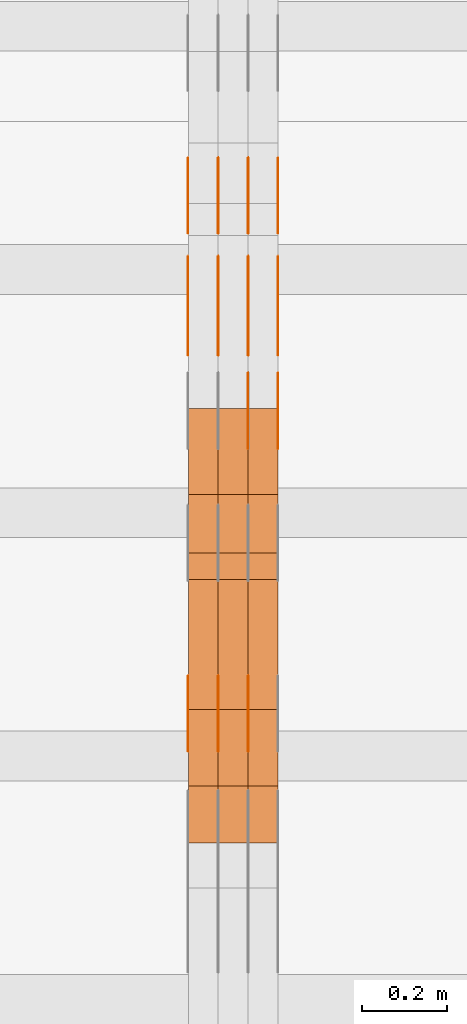
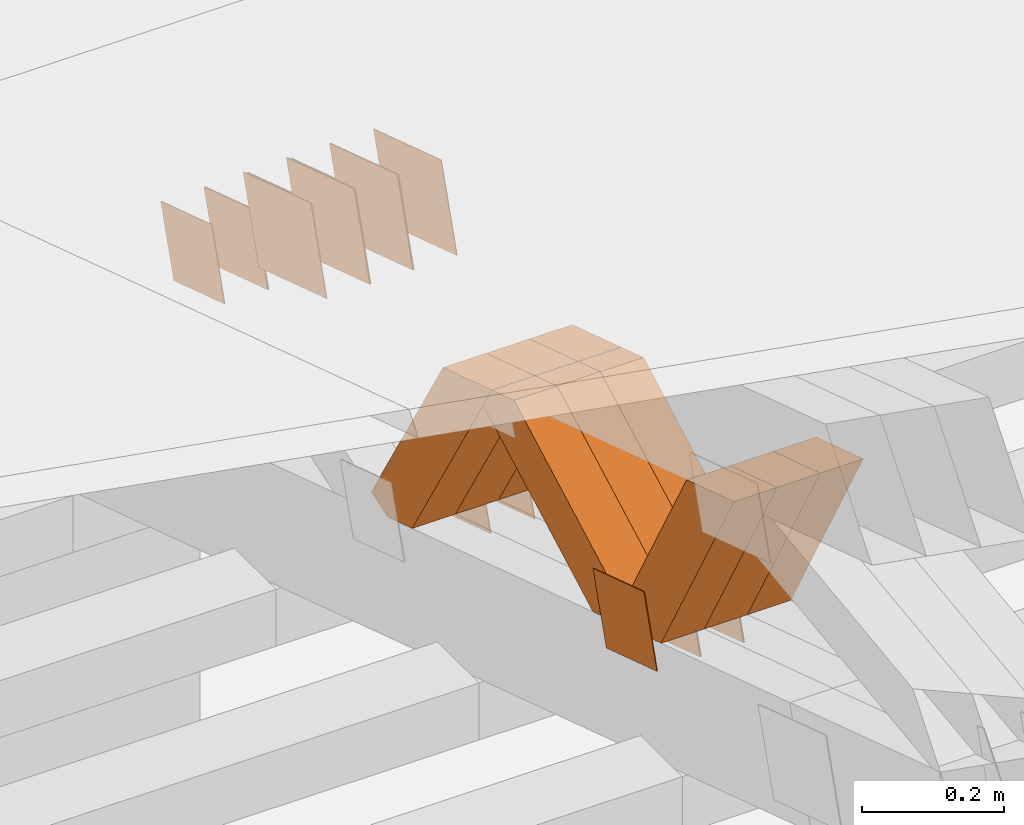
# One storey, part 196 of 385: 28 proxies.
"""IFC2X3 building model written with IfcOpenShell, lengths in millimetres."""

from ifc_helpers import new_model, entity, si_unit, converted_unit, derived_unit, direction, frame, origin, place, context, subcontext, project, spatial, polyline, outline, extrude, source, transform, mapped, material, type_object, type_shapes, element, save


model = new_model("IFC2X3")

# Units and contexts
model_context = context("Model", 3, precision=0.01, world=origin(), true_north=direction((6.12303176911189e-17, 1.0)))
body_context = subcontext(model_context, "Body", "Model", "MODEL_VIEW")
ifc_project = project(units=[si_unit("LENGTHUNIT", "METRE", prefix="MILLI"), si_unit("AREAUNIT", "SQUARE_METRE"), si_unit("VOLUMEUNIT", "CUBIC_METRE"), converted_unit("PLANEANGLEUNIT", "DEGREE", entity("IfcRatioMeasure", 0.0174532925199433), si_unit("PLANEANGLEUNIT", "RADIAN"), dimensions=[0, 0, 0, 0, 0, 0, 0]), si_unit("MASSUNIT", "GRAM", prefix="KILO"), derived_unit("MASSDENSITYUNIT", [(si_unit("MASSUNIT", "GRAM", prefix="KILO"), 1), (si_unit("LENGTHUNIT", "METRE"), -3)]), si_unit("TIMEUNIT", "SECOND"), si_unit("FREQUENCYUNIT", "HERTZ"), si_unit("THERMODYNAMICTEMPERATUREUNIT", "DEGREE_CELSIUS"), derived_unit("THERMALTRANSMITTANCEUNIT", [(si_unit("MASSUNIT", "GRAM", prefix="KILO"), 1), (si_unit("THERMODYNAMICTEMPERATUREUNIT", "KELVIN"), -1), (si_unit("TIMEUNIT", "SECOND"), -3)]), derived_unit("VOLUMETRICFLOWRATEUNIT", [(si_unit("LENGTHUNIT", "METRE"), 3), (si_unit("TIMEUNIT", "SECOND"), -1)]), si_unit("ELECTRICCURRENTUNIT", "AMPERE"), si_unit("ELECTRICVOLTAGEUNIT", "VOLT"), si_unit("POWERUNIT", "WATT"), si_unit("FORCEUNIT", "NEWTON", prefix="KILO"), si_unit("ILLUMINANCEUNIT", "LUX"), si_unit("LUMINOUSFLUXUNIT", "LUMEN"), si_unit("LUMINOUSINTENSITYUNIT", "CANDELA"), derived_unit("USERDEFINED", [(si_unit("MASSUNIT", "GRAM", prefix="KILO"), -1), (si_unit("LENGTHUNIT", "METRE"), -2), (si_unit("TIMEUNIT", "SECOND"), 3), (si_unit("LUMINOUSFLUXUNIT", "LUMEN"), 1)]), derived_unit("LINEARVELOCITYUNIT", [(si_unit("LENGTHUNIT", "METRE"), 1), (si_unit("TIMEUNIT", "SECOND"), -1)]), si_unit("PRESSUREUNIT", "PASCAL"), derived_unit("USERDEFINED", [(si_unit("LENGTHUNIT", "METRE"), -2), (si_unit("MASSUNIT", "GRAM", prefix="KILO"), 1), (si_unit("TIMEUNIT", "SECOND"), -2)])], contexts=[model_context])

# Site, building, storey
site_placement = place(None, origin())
site = spatial("IfcSite", under=ifc_project, at=site_placement, CompositionType="ELEMENT")
building_placement = place(site_placement, origin())
building = spatial("IfcBuilding", under=site, at=building_placement, CompositionType="ELEMENT")
storey_placement = place(building_placement, origin())
storey = spatial("IfcBuildingStorey", under=building, at=storey_placement, Name="Default", CompositionType="ELEMENT", Elevation=0.0)

# Proxies
ifc_material_1 = material(Name="IfcSurfaceStyle #212218")
building_element_proxy_type_1 = type_object("IfcBuildingElementProxyType", PredefinedType="NOTDEFINED", material=ifc_material_1)
shared_shape_1 = source(origin(), body_context, "Body", "SweptSolid", [
    extrude(outline(polyline([(-74.9998605591059, -59.9999264677526), (74.999875428623, -59.9999264677526), (74.9998605591068, 59.9999264677526), (-74.9998754286239, 59.9999264677526), (-74.9998605591059, -59.9999264677526)])), frame((75.0000889884782, 60.0000460315623, 0.0), z_axis=(0.0, 0.0, 1.0), x_axis=(-1.0, 0.0, 0.0)), (0.0, 0.0, 1.0), 1.3),
])
type_shapes(building_element_proxy_type_1, [shared_shape_1])
proxy_1_placement = place(building_placement, frame((15386.3, 20621.9679769682, 2241.76551219004), z_axis=(-1.0, 0.0, 0.0), x_axis=(0.0, -0.951056516295154, 0.309016994374948)))
element("IfcBuildingElementProxy", 1, at=proxy_1_placement, inside=storey, type_object=building_element_proxy_type_1, material=ifc_material_1, context=body_context, shape_type="MappedRepresentation", body=[
    mapped(shared_shape_1, transform((0.0, 0.0, 0.0), scale=1.0)),
])
ifc_material_2 = material(Name="IfcSurfaceStyle #212161")
building_element_proxy_type_2 = type_object("IfcBuildingElementProxyType", PredefinedType="NOTDEFINED", material=ifc_material_2)
shared_shape_2 = source(origin(), body_context, "Body", "SweptSolid", [
    extrude(outline(polyline([(-74.9998605591059, -59.9999264677526), (74.999875428623, -59.9999264677526), (74.9998605591068, 59.9999264677526), (-74.9998754286239, 59.9999264677526), (-74.9998605591059, -59.9999264677526)])), frame((75.0000889884782, 60.0000460315623, 0.0), z_axis=(0.0, 0.0, 1.0), x_axis=(-1.0, 0.0, 0.0)), (0.0, 0.0, 1.0), 1.3),
])
type_shapes(building_element_proxy_type_2, [shared_shape_2])
proxy_2_placement = place(building_placement, frame((15315.0, 20621.9679769682, 2241.76551219004), z_axis=(-1.0, 0.0, 0.0), x_axis=(0.0, -0.951056516295154, 0.309016994374948)))
element("IfcBuildingElementProxy", 2, at=proxy_2_placement, inside=storey, type_object=building_element_proxy_type_2, material=ifc_material_2, context=body_context, shape_type="MappedRepresentation", body=[
    mapped(shared_shape_2, transform((0.0, 0.0, 0.0), scale=1.0)),
])
ifc_material_3 = material(Name="IfcSurfaceStyle #212104")
building_element_proxy_type_3 = type_object("IfcBuildingElementProxyType", PredefinedType="NOTDEFINED", material=ifc_material_3)
shared_shape_3 = source(origin(), body_context, "Body", "SweptSolid", [
    extrude(outline(polyline([(-74.9998605591059, -59.9999264677526), (74.999875428623, -59.9999264677526), (74.9998605591068, 59.9999264677526), (-74.9998754286239, 59.9999264677526), (-74.9998605591059, -59.9999264677526)])), frame((75.0000889884782, 60.0000460315623, 0.0), z_axis=(0.0, 0.0, 1.0), x_axis=(-1.0, 0.0, 0.0)), (0.0, 0.0, 1.0), 1.3),
])
type_shapes(building_element_proxy_type_3, [shared_shape_3])
proxy_3_placement = place(building_placement, frame((15316.3, 20621.9679769682, 2241.76551219004), z_axis=(-1.0, 0.0, 0.0), x_axis=(0.0, -0.951056516295154, 0.309016994374948)))
element("IfcBuildingElementProxy", 3, at=proxy_3_placement, inside=storey, type_object=building_element_proxy_type_3, material=ifc_material_3, context=body_context, shape_type="MappedRepresentation", body=[
    mapped(shared_shape_3, transform((0.0, 0.0, 0.0), scale=1.0)),
])
ifc_material_4 = material(Name="IfcSurfaceStyle #212047")
building_element_proxy_type_4 = type_object("IfcBuildingElementProxyType", PredefinedType="NOTDEFINED", material=ifc_material_4)
shared_shape_4 = source(origin(), body_context, "Body", "SweptSolid", [
    extrude(outline(polyline([(-74.9998605591059, -59.9999264677526), (74.999875428623, -59.9999264677526), (74.9998605591068, 59.9999264677526), (-74.9998754286239, 59.9999264677526), (-74.9998605591059, -59.9999264677526)])), frame((75.0000889884782, 60.0000460315623, 0.0), z_axis=(0.0, 0.0, 1.0), x_axis=(-1.0, 0.0, 0.0)), (0.0, 0.0, 1.0), 1.29999999999999),
])
type_shapes(building_element_proxy_type_4, [shared_shape_4])
proxy_4_placement = place(building_placement, frame((15245.0, 20621.9679769682, 2241.76551219004), z_axis=(-1.0, 0.0, 0.0), x_axis=(0.0, -0.951056516295154, 0.309016994374948)))
element("IfcBuildingElementProxy", 4, at=proxy_4_placement, inside=storey, type_object=building_element_proxy_type_4, material=ifc_material_4, context=body_context, shape_type="MappedRepresentation", body=[
    mapped(shared_shape_4, transform((0.0, 0.0, 0.0), scale=1.0)),
])
ifc_material_5 = material(Name="IfcSurfaceStyle #211990")
building_element_proxy_type_5 = type_object("IfcBuildingElementProxyType", PredefinedType="NOTDEFINED", material=ifc_material_5)
shared_shape_5 = source(origin(), body_context, "Body", "SweptSolid", [
    extrude(outline(polyline([(-74.9998605591059, -59.9999264677526), (74.999875428623, -59.9999264677526), (74.9998605591068, 59.9999264677526), (-74.9998754286239, 59.9999264677526), (-74.9998605591059, -59.9999264677526)])), frame((75.0000889884782, 60.0000460315623, 0.0), z_axis=(0.0, 0.0, 1.0), x_axis=(-1.0, 0.0, 0.0)), (0.0, 0.0, 1.0), 1.29999999999999),
])
type_shapes(building_element_proxy_type_5, [shared_shape_5])
proxy_5_placement = place(building_placement, frame((15246.3, 20621.9679769682, 2241.76551219004), z_axis=(-1.0, 0.0, 0.0), x_axis=(0.0, -0.951056516295154, 0.309016994374948)))
element("IfcBuildingElementProxy", 5, at=proxy_5_placement, inside=storey, type_object=building_element_proxy_type_5, material=ifc_material_5, context=body_context, shape_type="MappedRepresentation", body=[
    mapped(shared_shape_5, transform((0.0, 0.0, 0.0), scale=1.0)),
])
ifc_material_6 = material(Name="IfcSurfaceStyle #211933")
building_element_proxy_type_6 = type_object("IfcBuildingElementProxyType", PredefinedType="NOTDEFINED", material=ifc_material_6)
shared_shape_6 = source(origin(), body_context, "Body", "SweptSolid", [
    extrude(outline(polyline([(-74.9998605591059, -59.9999264677526), (74.999875428623, -59.9999264677526), (74.9998605591068, 59.9999264677526), (-74.9998754286239, 59.9999264677526), (-74.9998605591059, -59.9999264677526)])), frame((75.0000889884782, 60.0000460315623, 0.0), z_axis=(0.0, 0.0, 1.0), x_axis=(-1.0, 0.0, 0.0)), (0.0, 0.0, 1.0), 1.29999999999999),
])
type_shapes(building_element_proxy_type_6, [shared_shape_6])
proxy_6_placement = place(building_placement, frame((15175.0, 20621.9679769682, 2241.76551219004), z_axis=(-1.0, 0.0, 0.0), x_axis=(0.0, -0.951056516295154, 0.309016994374948)))
element("IfcBuildingElementProxy", 6, at=proxy_6_placement, inside=storey, type_object=building_element_proxy_type_6, material=ifc_material_6, context=body_context, shape_type="MappedRepresentation", body=[
    mapped(shared_shape_6, transform((0.0, 0.0, 0.0), scale=1.0)),
])
ifc_material_7 = material(Name="IfcSurfaceStyle #210508")
building_element_proxy_type_7 = type_object("IfcBuildingElementProxyType", PredefinedType="NOTDEFINED", material=ifc_material_7)
shared_shape_7 = source(origin(), body_context, "Body", "SweptSolid", [
    extrude(outline(polyline([(-100.000260677523, -72.0000050220369), (100.000341220114, -72.0000050220369), (99.9997962944585, 72.0000050220369), (-99.9998768370492, 72.0000050220369), (-100.000260677523, -72.0000050220369)])), frame((100.000341220114, 72.0001826453454, 0.0), z_axis=(0.0, 0.0, 1.0), x_axis=(-1.0, 0.0, 0.0)), (0.0, 0.0, 1.0), 1.3),
])
type_shapes(building_element_proxy_type_7, [shared_shape_7])
proxy_7_placement = place(building_placement, frame((15386.3, 20382.8706354426, 2409.35285895246), z_axis=(-1.0, 0.0, 0.0), x_axis=(0.0, -0.951056516295154, 0.309016994374948)))
element("IfcBuildingElementProxy", 7, at=proxy_7_placement, inside=storey, type_object=building_element_proxy_type_7, material=ifc_material_7, context=body_context, shape_type="MappedRepresentation", body=[
    mapped(shared_shape_7, transform((0.0, 0.0, 0.0), scale=1.0)),
])
ifc_material_8 = material(Name="IfcSurfaceStyle #210451")
building_element_proxy_type_8 = type_object("IfcBuildingElementProxyType", PredefinedType="NOTDEFINED", material=ifc_material_8)
shared_shape_8 = source(origin(), body_context, "Body", "SweptSolid", [
    extrude(outline(polyline([(-100.000260677523, -72.0000050220369), (100.000341220114, -72.0000050220369), (99.9997962944585, 72.0000050220369), (-99.9998768370492, 72.0000050220369), (-100.000260677523, -72.0000050220369)])), frame((100.000341220114, 72.0001826453454, 0.0), z_axis=(0.0, 0.0, 1.0), x_axis=(-1.0, 0.0, 0.0)), (0.0, 0.0, 1.0), 1.3),
])
type_shapes(building_element_proxy_type_8, [shared_shape_8])
proxy_8_placement = place(building_placement, frame((15315.0, 20382.8706354426, 2409.35285895246), z_axis=(-1.0, 0.0, 0.0), x_axis=(0.0, -0.951056516295154, 0.309016994374948)))
element("IfcBuildingElementProxy", 8, at=proxy_8_placement, inside=storey, type_object=building_element_proxy_type_8, material=ifc_material_8, context=body_context, shape_type="MappedRepresentation", body=[
    mapped(shared_shape_8, transform((0.0, 0.0, 0.0), scale=1.0)),
])
ifc_material_9 = material(Name="IfcSurfaceStyle #210394")
building_element_proxy_type_9 = type_object("IfcBuildingElementProxyType", PredefinedType="NOTDEFINED", material=ifc_material_9)
shared_shape_9 = source(origin(), body_context, "Body", "SweptSolid", [
    extrude(outline(polyline([(-100.000260677523, -72.0000050220369), (100.000341220114, -72.0000050220369), (99.9997962944585, 72.0000050220369), (-99.9998768370492, 72.0000050220369), (-100.000260677523, -72.0000050220369)])), frame((100.000341220114, 72.0001826453454, 0.0), z_axis=(0.0, 0.0, 1.0), x_axis=(-1.0, 0.0, 0.0)), (0.0, 0.0, 1.0), 1.3),
])
type_shapes(building_element_proxy_type_9, [shared_shape_9])
proxy_9_placement = place(building_placement, frame((15316.3, 20382.8706354426, 2409.35285895246), z_axis=(-1.0, 0.0, 0.0), x_axis=(0.0, -0.951056516295154, 0.309016994374948)))
element("IfcBuildingElementProxy", 9, at=proxy_9_placement, inside=storey, type_object=building_element_proxy_type_9, material=ifc_material_9, context=body_context, shape_type="MappedRepresentation", body=[
    mapped(shared_shape_9, transform((0.0, 0.0, 0.0), scale=1.0)),
])
ifc_material_10 = material(Name="IfcSurfaceStyle #210337")
building_element_proxy_type_10 = type_object("IfcBuildingElementProxyType", PredefinedType="NOTDEFINED", material=ifc_material_10)
shared_shape_10 = source(origin(), body_context, "Body", "SweptSolid", [
    extrude(outline(polyline([(-100.000260677523, -72.0000050220369), (100.000341220114, -72.0000050220369), (99.9997962944585, 72.0000050220369), (-99.9998768370492, 72.0000050220369), (-100.000260677523, -72.0000050220369)])), frame((100.000341220114, 72.0001826453454, 0.0), z_axis=(0.0, 0.0, 1.0), x_axis=(-1.0, 0.0, 0.0)), (0.0, 0.0, 1.0), 1.29999999999998),
])
type_shapes(building_element_proxy_type_10, [shared_shape_10])
proxy_10_placement = place(building_placement, frame((15245.0, 20382.8706354426, 2409.35285895246), z_axis=(-1.0, 0.0, 0.0), x_axis=(0.0, -0.951056516295154, 0.309016994374948)))
element("IfcBuildingElementProxy", 10, at=proxy_10_placement, inside=storey, type_object=building_element_proxy_type_10, material=ifc_material_10, context=body_context, shape_type="MappedRepresentation", body=[
    mapped(shared_shape_10, transform((0.0, 0.0, 0.0), scale=1.0)),
])
ifc_material_11 = material(Name="IfcSurfaceStyle #210280")
building_element_proxy_type_11 = type_object("IfcBuildingElementProxyType", PredefinedType="NOTDEFINED", material=ifc_material_11)
shared_shape_11 = source(origin(), body_context, "Body", "SweptSolid", [
    extrude(outline(polyline([(-100.000260677523, -72.0000050220369), (100.000341220114, -72.0000050220369), (99.9997962944585, 72.0000050220369), (-99.9998768370492, 72.0000050220369), (-100.000260677523, -72.0000050220369)])), frame((100.000341220114, 72.0001826453454, 0.0), z_axis=(0.0, 0.0, 1.0), x_axis=(-1.0, 0.0, 0.0)), (0.0, 0.0, 1.0), 1.29999999999998),
])
type_shapes(building_element_proxy_type_11, [shared_shape_11])
proxy_11_placement = place(building_placement, frame((15246.3, 20382.8706354426, 2409.35285895246), z_axis=(-1.0, 0.0, 0.0), x_axis=(0.0, -0.951056516295154, 0.309016994374948)))
element("IfcBuildingElementProxy", 11, at=proxy_11_placement, inside=storey, type_object=building_element_proxy_type_11, material=ifc_material_11, context=body_context, shape_type="MappedRepresentation", body=[
    mapped(shared_shape_11, transform((0.0, 0.0, 0.0), scale=1.0)),
])
ifc_material_12 = material(Name="IfcSurfaceStyle #210223")
building_element_proxy_type_12 = type_object("IfcBuildingElementProxyType", PredefinedType="NOTDEFINED", material=ifc_material_12)
shared_shape_12 = source(origin(), body_context, "Body", "SweptSolid", [
    extrude(outline(polyline([(-100.000260677523, -72.0000050220369), (100.000341220114, -72.0000050220369), (99.9997962944585, 72.0000050220369), (-99.9998768370492, 72.0000050220369), (-100.000260677523, -72.0000050220369)])), frame((100.000341220114, 72.0001826453454, 0.0), z_axis=(0.0, 0.0, 1.0), x_axis=(-1.0, 0.0, 0.0)), (0.0, 0.0, 1.0), 1.29999999999999),
])
type_shapes(building_element_proxy_type_12, [shared_shape_12])
proxy_12_placement = place(building_placement, frame((15175.0, 20382.8706354426, 2409.35285895246), z_axis=(-1.0, 0.0, 0.0), x_axis=(0.0, -0.951056516295154, 0.309016994374948)))
element("IfcBuildingElementProxy", 12, at=proxy_12_placement, inside=storey, type_object=building_element_proxy_type_12, material=ifc_material_12, context=body_context, shape_type="MappedRepresentation", body=[
    mapped(shared_shape_12, transform((0.0, 0.0, 0.0), scale=1.0)),
])
ifc_material_13 = material(Name="IfcSurfaceStyle #204295")
building_element_proxy_type_13 = type_object("IfcBuildingElementProxyType", PredefinedType="NOTDEFINED", material=ifc_material_13)
shared_shape_13 = source(origin(), body_context, "Body", "SweptSolid", [
    extrude(outline(polyline([(-74.9998605591127, -59.9999264677599), (74.999875428618, -59.9999264677599), (74.9998605591127, 59.9999264677599), (-74.999875428618, 59.9999264677599), (-74.9998605591127, -59.9999264677599)])), frame((75.0002655673825, 60.0000016373433, 0.0), z_axis=(0.0, 0.0, 1.0), x_axis=(-1.0, 0.0, 0.0)), (0.0, 0.0, 1.0), 1.3),
])
type_shapes(building_element_proxy_type_13, [shared_shape_13])
proxy_13_placement = place(building_placement, frame((15315.0, 19407.1136664358, 2348.71056820494), z_axis=(-1.0, 0.0, 0.0), x_axis=(0.0, -0.951056516295124, 0.309016994375039)))
element("IfcBuildingElementProxy", 13, at=proxy_13_placement, inside=storey, type_object=building_element_proxy_type_13, material=ifc_material_13, context=body_context, shape_type="MappedRepresentation", body=[
    mapped(shared_shape_13, transform((0.0, 0.0, 0.0), scale=1.0)),
])
ifc_material_14 = material(Name="IfcSurfaceStyle #204238")
building_element_proxy_type_14 = type_object("IfcBuildingElementProxyType", PredefinedType="NOTDEFINED", material=ifc_material_14)
shared_shape_14 = source(origin(), body_context, "Body", "SweptSolid", [
    extrude(outline(polyline([(-74.9998605591127, -59.9999264677599), (74.999875428618, -59.9999264677599), (74.9998605591127, 59.9999264677599), (-74.999875428618, 59.9999264677599), (-74.9998605591127, -59.9999264677599)])), frame((75.0002655673825, 60.0000016373433, 0.0), z_axis=(0.0, 0.0, 1.0), x_axis=(-1.0, 0.0, 0.0)), (0.0, 0.0, 1.0), 1.3),
])
type_shapes(building_element_proxy_type_14, [shared_shape_14])
proxy_14_placement = place(building_placement, frame((15316.3, 19407.1136664358, 2348.71056820494), z_axis=(-1.0, 0.0, 0.0), x_axis=(0.0, -0.951056516295124, 0.309016994375039)))
element("IfcBuildingElementProxy", 14, at=proxy_14_placement, inside=storey, type_object=building_element_proxy_type_14, material=ifc_material_14, context=body_context, shape_type="MappedRepresentation", body=[
    mapped(shared_shape_14, transform((0.0, 0.0, 0.0), scale=1.0)),
])
ifc_material_15 = material(Name="IfcSurfaceStyle #204181")
building_element_proxy_type_15 = type_object("IfcBuildingElementProxyType", PredefinedType="NOTDEFINED", material=ifc_material_15)
shared_shape_15 = source(origin(), body_context, "Body", "SweptSolid", [
    extrude(outline(polyline([(-74.9998605591127, -59.9999264677599), (74.999875428618, -59.9999264677599), (74.9998605591127, 59.9999264677599), (-74.999875428618, 59.9999264677599), (-74.9998605591127, -59.9999264677599)])), frame((75.0002655673825, 60.0000016373433, 0.0), z_axis=(0.0, 0.0, 1.0), x_axis=(-1.0, 0.0, 0.0)), (0.0, 0.0, 1.0), 1.29999999999999),
])
type_shapes(building_element_proxy_type_15, [shared_shape_15])
proxy_15_placement = place(building_placement, frame((15245.0, 19407.1136664358, 2348.71056820494), z_axis=(-1.0, 0.0, 0.0), x_axis=(0.0, -0.951056516295124, 0.309016994375039)))
element("IfcBuildingElementProxy", 15, at=proxy_15_placement, inside=storey, type_object=building_element_proxy_type_15, material=ifc_material_15, context=body_context, shape_type="MappedRepresentation", body=[
    mapped(shared_shape_15, transform((0.0, 0.0, 0.0), scale=1.0)),
])
ifc_material_16 = material(Name="IfcSurfaceStyle #204124")
building_element_proxy_type_16 = type_object("IfcBuildingElementProxyType", PredefinedType="NOTDEFINED", material=ifc_material_16)
shared_shape_16 = source(origin(), body_context, "Body", "SweptSolid", [
    extrude(outline(polyline([(-74.9998605591127, -59.9999264677599), (74.999875428618, -59.9999264677599), (74.9998605591127, 59.9999264677599), (-74.999875428618, 59.9999264677599), (-74.9998605591127, -59.9999264677599)])), frame((75.0002655673825, 60.0000016373433, 0.0), z_axis=(0.0, 0.0, 1.0), x_axis=(-1.0, 0.0, 0.0)), (0.0, 0.0, 1.0), 1.29999999999999),
])
type_shapes(building_element_proxy_type_16, [shared_shape_16])
proxy_16_placement = place(building_placement, frame((15246.3, 19407.1136664358, 2348.71056820494), z_axis=(-1.0, 0.0, 0.0), x_axis=(0.0, -0.951056516295124, 0.309016994375039)))
element("IfcBuildingElementProxy", 16, at=proxy_16_placement, inside=storey, type_object=building_element_proxy_type_16, material=ifc_material_16, context=body_context, shape_type="MappedRepresentation", body=[
    mapped(shared_shape_16, transform((0.0, 0.0, 0.0), scale=1.0)),
])
ifc_material_17 = material(Name="IfcSurfaceStyle #204067")
building_element_proxy_type_17 = type_object("IfcBuildingElementProxyType", PredefinedType="NOTDEFINED", material=ifc_material_17)
shared_shape_17 = source(origin(), body_context, "Body", "SweptSolid", [
    extrude(outline(polyline([(-74.9998605591127, -59.9999264677599), (74.999875428618, -59.9999264677599), (74.9998605591127, 59.9999264677599), (-74.999875428618, 59.9999264677599), (-74.9998605591127, -59.9999264677599)])), frame((75.0002655673825, 60.0000016373433, 0.0), z_axis=(0.0, 0.0, 1.0), x_axis=(-1.0, 0.0, 0.0)), (0.0, 0.0, 1.0), 1.29999999999999),
])
type_shapes(building_element_proxy_type_17, [shared_shape_17])
proxy_17_placement = place(building_placement, frame((15175.0, 19407.1136664358, 2348.71056820494), z_axis=(-1.0, 0.0, 0.0), x_axis=(0.0, -0.951056516295124, 0.309016994375039)))
element("IfcBuildingElementProxy", 17, at=proxy_17_placement, inside=storey, type_object=building_element_proxy_type_17, material=ifc_material_17, context=body_context, shape_type="MappedRepresentation", body=[
    mapped(shared_shape_17, transform((0.0, 0.0, 0.0), scale=1.0)),
])
ifc_material_18 = material(Name="IfcSurfaceStyle #204010")
building_element_proxy_type_18 = type_object("IfcBuildingElementProxyType", PredefinedType="NOTDEFINED", material=ifc_material_18)
shared_shape_18 = source(origin(), body_context, "Body", "SweptSolid", [
    extrude(outline(polyline([(-74.9998605591118, -59.9999264677598), (74.9998754286171, -59.9999264677598), (74.9998605591136, 59.9999264677598), (-74.9998754286189, 59.9999264677598), (-74.9998605591118, -59.9999264677598)])), frame((75.0000347664736, 60.0000016373434, 0.0), z_axis=(0.0, 0.0, 1.0), x_axis=(-1.0, 0.0, 0.0)), (0.0, 0.0, 1.0), 1.3),
])
type_shapes(building_element_proxy_type_18, [shared_shape_18])
proxy_18_placement = place(building_placement, frame((15386.3, 20117.0890328685, 2105.40814929196), z_axis=(-1.0, 0.0, 0.0), x_axis=(0.0, -0.951056516295124, 0.309016994375039)))
element("IfcBuildingElementProxy", 18, at=proxy_18_placement, inside=storey, type_object=building_element_proxy_type_18, material=ifc_material_18, context=body_context, shape_type="MappedRepresentation", body=[
    mapped(shared_shape_18, transform((0.0, 0.0, 0.0), scale=1.0)),
])
ifc_material_19 = material(Name="IfcSurfaceStyle #203953")
building_element_proxy_type_19 = type_object("IfcBuildingElementProxyType", PredefinedType="NOTDEFINED", material=ifc_material_19)
shared_shape_19 = source(origin(), body_context, "Body", "SweptSolid", [
    extrude(outline(polyline([(-74.9998605591118, -59.9999264677598), (74.9998754286171, -59.9999264677598), (74.9998605591136, 59.9999264677598), (-74.9998754286189, 59.9999264677598), (-74.9998605591118, -59.9999264677598)])), frame((75.0000347664736, 60.0000016373434, 0.0), z_axis=(0.0, 0.0, 1.0), x_axis=(-1.0, 0.0, 0.0)), (0.0, 0.0, 1.0), 1.3),
])
type_shapes(building_element_proxy_type_19, [shared_shape_19])
proxy_19_placement = place(building_placement, frame((15315.0, 20117.0890328685, 2105.40814929196), z_axis=(-1.0, 0.0, 0.0), x_axis=(0.0, -0.951056516295124, 0.309016994375039)))
element("IfcBuildingElementProxy", 19, at=proxy_19_placement, inside=storey, type_object=building_element_proxy_type_19, material=ifc_material_19, context=body_context, shape_type="MappedRepresentation", body=[
    mapped(shared_shape_19, transform((0.0, 0.0, 0.0), scale=1.0)),
])
ifc_material_20 = material(Name="IfcSurfaceStyle #187594")
building_element_proxy_type_20 = type_object("IfcBuildingElementProxyType", Name="T1-W40 187592", PredefinedType="NOTDEFINED", material=ifc_material_20)
shared_shape_20 = source(origin(), body_context, "Body", "SweptSolid", [
    extrude(outline(polyline([(-190.697067347251, -47.4992767218045), (178.704677543904, -47.4992767218045), (178.119540532346, -0.000296092407564622), (126.935785980356, 47.4999913795318), (-293.062936709355, 47.4988581564849), (-190.697067347251, -47.4992767218045)])), frame((178.7049897723, 47.4999913795318, 0.0), z_axis=(0.0, 0.0, 1.0), x_axis=(-1.0, 0.0, 0.0)), (0.0, 0.0, 1.0), 70.0),
])
type_shapes(building_element_proxy_type_20, [shared_shape_20])
proxy_20_placement = place(building_placement, frame((15385.0, 19280.269490882, 2403.36730959494), z_axis=(-1.0, 0.0, 0.0), x_axis=(0.0, -0.48691092455798, 0.873451630913866)))
element("IfcBuildingElementProxy", 20, at=proxy_20_placement, inside=storey, type_object=building_element_proxy_type_20, material=ifc_material_20, Name="T1-W40", context=body_context, shape_type="MappedRepresentation", body=[
    mapped(shared_shape_20, transform((0.0, 0.0, 0.0), scale=1.0)),
])
ifc_material_21 = material(Name="IfcSurfaceStyle #187528")
building_element_proxy_type_21 = type_object("IfcBuildingElementProxyType", Name="T1-W40 187526", PredefinedType="NOTDEFINED", material=ifc_material_21)
shared_shape_21 = source(origin(), body_context, "Body", "SweptSolid", [
    extrude(outline(polyline([(-190.697067347251, -47.4992767218045), (178.704677543904, -47.4992767218045), (178.119540532346, -0.000296092407564622), (126.935785980356, 47.4999913795318), (-293.062936709355, 47.4988581564849), (-190.697067347251, -47.4992767218045)])), frame((178.7049897723, 47.4999913795318, 0.0), z_axis=(0.0, 0.0, 1.0), x_axis=(-1.0, 0.0, 0.0)), (0.0, 0.0, 1.0), 70.0),
])
type_shapes(building_element_proxy_type_21, [shared_shape_21])
proxy_21_placement = place(building_placement, frame((15315.0, 19280.269490882, 2403.36730959494), z_axis=(-1.0, 0.0, 0.0), x_axis=(0.0, -0.48691092455798, 0.873451630913866)))
element("IfcBuildingElementProxy", 21, at=proxy_21_placement, inside=storey, type_object=building_element_proxy_type_21, material=ifc_material_21, Name="T1-W40", context=body_context, shape_type="MappedRepresentation", body=[
    mapped(shared_shape_21, transform((0.0, 0.0, 0.0), scale=1.0)),
])
ifc_material_22 = material(Name="IfcSurfaceStyle #187462")
building_element_proxy_type_22 = type_object("IfcBuildingElementProxyType", Name="T1-W40 187460", PredefinedType="NOTDEFINED", material=ifc_material_22)
shared_shape_22 = source(origin(), body_context, "Body", "SweptSolid", [
    extrude(outline(polyline([(-190.697067347251, -47.4992767218045), (178.704677543904, -47.4992767218045), (178.119540532346, -0.000296092407564622), (126.935785980356, 47.4999913795318), (-293.062936709355, 47.4988581564849), (-190.697067347251, -47.4992767218045)])), frame((178.7049897723, 47.4999913795318, 0.0), z_axis=(0.0, 0.0, 1.0), x_axis=(-1.0, 0.0, 0.0)), (0.0, 0.0, 1.0), 70.0),
])
type_shapes(building_element_proxy_type_22, [shared_shape_22])
proxy_22_placement = place(building_placement, frame((15245.0, 19280.269490882, 2403.36730959494), z_axis=(-1.0, 0.0, 0.0), x_axis=(0.0, -0.48691092455798, 0.873451630913866)))
element("IfcBuildingElementProxy", 22, at=proxy_22_placement, inside=storey, type_object=building_element_proxy_type_22, material=ifc_material_22, Name="T1-W40", context=body_context, shape_type="MappedRepresentation", body=[
    mapped(shared_shape_22, transform((0.0, 0.0, 0.0), scale=1.0)),
])
ifc_material_23 = material(Name="IfcSurfaceStyle #187198")
building_element_proxy_type_23 = type_object("IfcBuildingElementProxyType", Name="T1-W47 187196", PredefinedType="NOTDEFINED", material=ifc_material_23)
shared_shape_23 = source(origin(), body_context, "Body", "SweptSolid", [
    extrude(outline(polyline([(-273.154581805017, -47.5000119135351), (121.157675769026, -47.5000119135351), (166.341960897813, -0.000128144957132403), (168.441931699108, 47.5000759860137), (-182.78698656093, 47.5000759860137), (-273.154581805017, -47.5000119135351)])), frame((168.441931699108, 47.5000759860137, 0.0), z_axis=(0.0, 0.0, 1.0), x_axis=(-1.0, 0.0, 0.0)), (0.0, 0.0, 1.0), 70.0),
])
type_shapes(building_element_proxy_type_23, [shared_shape_23])
proxy_23_placement = place(building_placement, frame((15385.0, 19755.0380859375, 2553.712890625), z_axis=(-1.0, 0.0, 0.0), x_axis=(0.0, -0.879386813332609, -0.476108005117242)))
element("IfcBuildingElementProxy", 23, at=proxy_23_placement, inside=storey, type_object=building_element_proxy_type_23, material=ifc_material_23, Name="T1-W47", context=body_context, shape_type="MappedRepresentation", body=[
    mapped(shared_shape_23, transform((0.0, 0.0, 0.0), scale=1.0)),
])
ifc_material_24 = material(Name="IfcSurfaceStyle #187132")
building_element_proxy_type_24 = type_object("IfcBuildingElementProxyType", Name="T1-W47 187130", PredefinedType="NOTDEFINED", material=ifc_material_24)
shared_shape_24 = source(origin(), body_context, "Body", "SweptSolid", [
    extrude(outline(polyline([(-273.154581805017, -47.5000119135351), (121.157675769026, -47.5000119135351), (166.341960897813, -0.000128144957132403), (168.441931699108, 47.5000759860137), (-182.78698656093, 47.5000759860137), (-273.154581805017, -47.5000119135351)])), frame((168.441931699108, 47.5000759860137, 0.0), z_axis=(0.0, 0.0, 1.0), x_axis=(-1.0, 0.0, 0.0)), (0.0, 0.0, 1.0), 70.0),
])
type_shapes(building_element_proxy_type_24, [shared_shape_24])
proxy_24_placement = place(building_placement, frame((15315.0, 19755.0380859375, 2553.712890625), z_axis=(-1.0, 0.0, 0.0), x_axis=(0.0, -0.879386813332609, -0.476108005117242)))
element("IfcBuildingElementProxy", 24, at=proxy_24_placement, inside=storey, type_object=building_element_proxy_type_24, material=ifc_material_24, Name="T1-W47", context=body_context, shape_type="MappedRepresentation", body=[
    mapped(shared_shape_24, transform((0.0, 0.0, 0.0), scale=1.0)),
])
ifc_material_25 = material(Name="IfcSurfaceStyle #187066")
building_element_proxy_type_25 = type_object("IfcBuildingElementProxyType", Name="T1-W47 187064", PredefinedType="NOTDEFINED", material=ifc_material_25)
shared_shape_25 = source(origin(), body_context, "Body", "SweptSolid", [
    extrude(outline(polyline([(-273.154581805017, -47.5000119135351), (121.157675769026, -47.5000119135351), (166.341960897813, -0.000128144957132403), (168.441931699108, 47.5000759860137), (-182.78698656093, 47.5000759860137), (-273.154581805017, -47.5000119135351)])), frame((168.441931699108, 47.5000759860137, 0.0), z_axis=(0.0, 0.0, 1.0), x_axis=(-1.0, 0.0, 0.0)), (0.0, 0.0, 1.0), 70.0),
])
type_shapes(building_element_proxy_type_25, [shared_shape_25])
proxy_25_placement = place(building_placement, frame((15245.0, 19755.0380859375, 2553.712890625), z_axis=(-1.0, 0.0, 0.0), x_axis=(0.0, -0.879386813332609, -0.476108005117242)))
element("IfcBuildingElementProxy", 25, at=proxy_25_placement, inside=storey, type_object=building_element_proxy_type_25, material=ifc_material_25, Name="T1-W47", context=body_context, shape_type="MappedRepresentation", body=[
    mapped(shared_shape_25, transform((0.0, 0.0, 0.0), scale=1.0)),
])
ifc_material_26 = material(Name="IfcSurfaceStyle #186802")
building_element_proxy_type_26 = type_object("IfcBuildingElementProxyType", Name="T1-W34 186800", PredefinedType="NOTDEFINED", material=ifc_material_26)
shared_shape_26 = source(origin(), body_context, "Body", "SweptSolid", [
    extrude(outline(polyline([(-197.657161937088, -47.499796538607), (193.17680883218, -47.499796538607), (182.92464491562, -1.98968224184526e-05), (128.354123102956, 47.4998064870182), (-306.798414913668, 47.4998064870182), (-197.657161937088, -47.499796538607)])), frame((193.176852028916, 47.4998566383869, 0.0), z_axis=(0.0, 0.0, 1.0), x_axis=(-1.0, 0.0, 0.0)), (0.0, 0.0, 1.0), 70.0),
])
type_shapes(building_element_proxy_type_26, [shared_shape_26])
proxy_26_placement = place(building_placement, frame((15385.0, 19987.8030409043, 2165.75390635484), z_axis=(-1.0, 0.0, 0.0), x_axis=(0.0, -0.514479403471631, 0.857502736674044)))
element("IfcBuildingElementProxy", 26, at=proxy_26_placement, inside=storey, type_object=building_element_proxy_type_26, material=ifc_material_26, Name="T1-W34", context=body_context, shape_type="MappedRepresentation", body=[
    mapped(shared_shape_26, transform((0.0, 0.0, 0.0), scale=1.0)),
])
ifc_material_27 = material(Name="IfcSurfaceStyle #186736")
building_element_proxy_type_27 = type_object("IfcBuildingElementProxyType", Name="T1-W34 186734", PredefinedType="NOTDEFINED", material=ifc_material_27)
shared_shape_27 = source(origin(), body_context, "Body", "SweptSolid", [
    extrude(outline(polyline([(-197.657161937088, -47.499796538607), (193.17680883218, -47.499796538607), (182.92464491562, -1.98968224184526e-05), (128.354123102956, 47.4998064870182), (-306.798414913668, 47.4998064870182), (-197.657161937088, -47.499796538607)])), frame((193.176852028916, 47.4998566383869, 0.0), z_axis=(0.0, 0.0, 1.0), x_axis=(-1.0, 0.0, 0.0)), (0.0, 0.0, 1.0), 70.0),
])
type_shapes(building_element_proxy_type_27, [shared_shape_27])
proxy_27_placement = place(building_placement, frame((15315.0, 19987.8030409043, 2165.75390635484), z_axis=(-1.0, 0.0, 0.0), x_axis=(0.0, -0.514479403471631, 0.857502736674044)))
element("IfcBuildingElementProxy", 27, at=proxy_27_placement, inside=storey, type_object=building_element_proxy_type_27, material=ifc_material_27, Name="T1-W34", context=body_context, shape_type="MappedRepresentation", body=[
    mapped(shared_shape_27, transform((0.0, 0.0, 0.0), scale=1.0)),
])
ifc_material_28 = material(Name="IfcSurfaceStyle #186670")
building_element_proxy_type_28 = type_object("IfcBuildingElementProxyType", Name="T1-W34 186668", PredefinedType="NOTDEFINED", material=ifc_material_28)
shared_shape_28 = source(origin(), body_context, "Body", "SweptSolid", [
    extrude(outline(polyline([(-197.657161937088, -47.499796538607), (193.17680883218, -47.499796538607), (182.92464491562, -1.98968224184526e-05), (128.354123102956, 47.4998064870182), (-306.798414913668, 47.4998064870182), (-197.657161937088, -47.499796538607)])), frame((193.176852028916, 47.4998566383869, 0.0), z_axis=(0.0, 0.0, 1.0), x_axis=(-1.0, 0.0, 0.0)), (0.0, 0.0, 1.0), 70.0),
])
type_shapes(building_element_proxy_type_28, [shared_shape_28])
proxy_28_placement = place(building_placement, frame((15245.0, 19987.8030409043, 2165.75390635484), z_axis=(-1.0, 0.0, 0.0), x_axis=(0.0, -0.514479403471631, 0.857502736674044)))
element("IfcBuildingElementProxy", 28, at=proxy_28_placement, inside=storey, type_object=building_element_proxy_type_28, material=ifc_material_28, Name="T1-W34", context=body_context, shape_type="MappedRepresentation", body=[
    mapped(shared_shape_28, transform((0.0, 0.0, 0.0), scale=1.0)),
])

save(model, "model.ifc")
